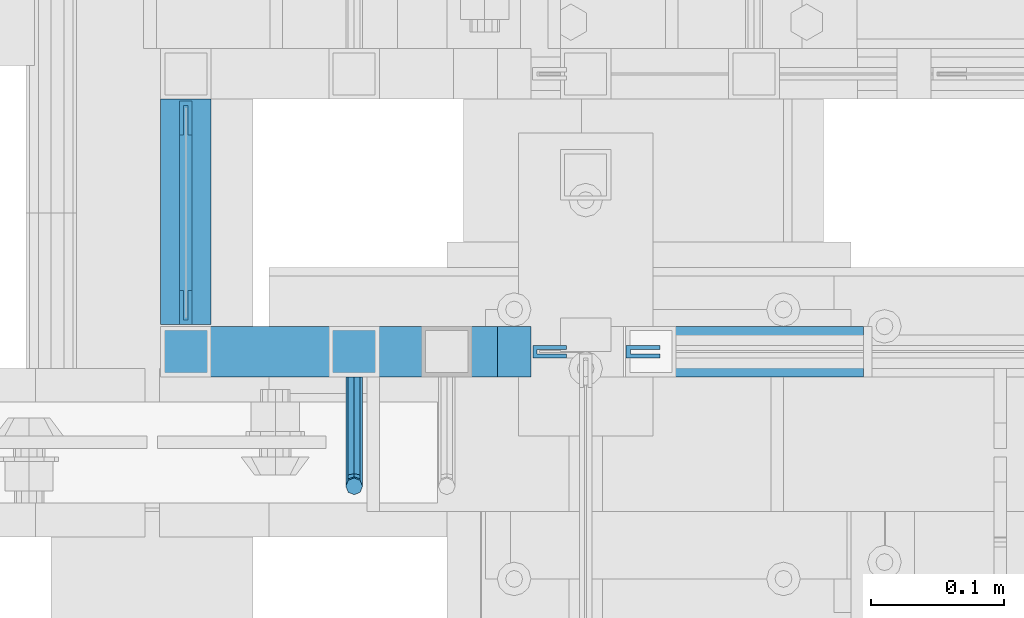
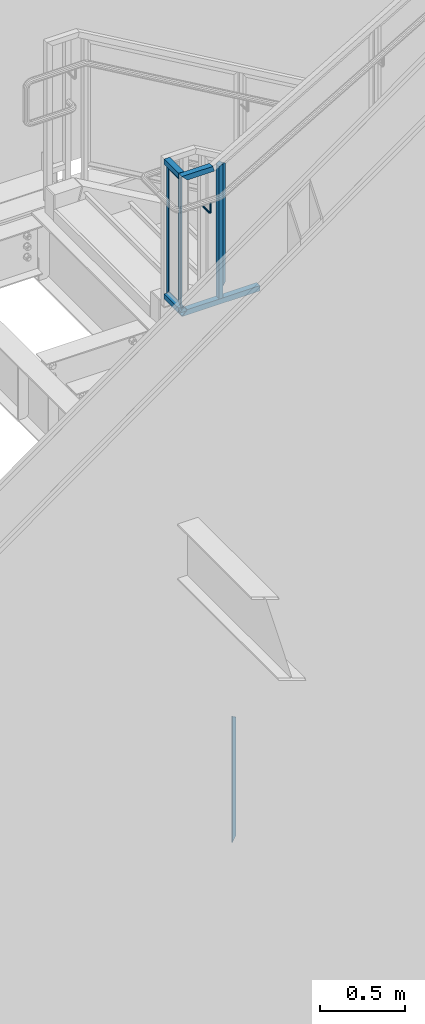
# One storey, part 908 of 1179: 9 beams, 2 members, 3 elements without a shape of their own.
"""IFC2X3 building model written with IfcOpenShell, lengths in millimetres."""

from ifc_helpers import new_model, si_unit, frame, origin_with_axes, place, context, subcontext, project, spatial, faceted_brep, material, type_object, element, aggregate, save


model = new_model("IFC2X3")

# Units and contexts
model_context = context("Model", 3, precision=1e-05, world=origin_with_axes())
body_context = subcontext(model_context, "Body", "Model", "MODEL_VIEW")
ifc_project = project(units=[si_unit("LENGTHUNIT", "METRE", prefix="MILLI"), si_unit("AREAUNIT", "SQUARE_METRE"), si_unit("VOLUMEUNIT", "CUBIC_METRE"), si_unit("MASSUNIT", "GRAM", prefix="KILO"), si_unit("TIMEUNIT", "SECOND"), si_unit("PLANEANGLEUNIT", "RADIAN"), si_unit("SOLIDANGLEUNIT", "STERADIAN"), si_unit("THERMODYNAMICTEMPERATUREUNIT", "DEGREE_CELSIUS"), si_unit("LUMINOUSINTENSITYUNIT", "LUMEN")], contexts=[model_context])

# Site, building, storey
site_placement = place(None, origin_with_axes())
site = spatial("IfcSite", under=ifc_project, at=site_placement, CompositionType="ELEMENT")
building_placement = place(site_placement, origin_with_axes())
building = spatial("IfcBuilding", under=site, at=building_placement, Name="Undefined", CompositionType="ELEMENT")
storey_placement = place(building_placement, origin_with_axes())
storey = spatial("IfcBuildingStorey", under=building, at=storey_placement, Name="Undefined", CompositionType="ELEMENT", Elevation=0.0)

# Assembly, member
assembly_1_placement = place(storey_placement, origin_with_axes())
assembly_1 = element("IfcElementAssembly", 1, at=assembly_1_placement, inside=storey, Name="GUARDRAIL", AssemblyPlace="NOTDEFINED", PredefinedType="RIGID_FRAME")
ifc_material_1 = material(Name="STEEL/A36")
member_type_1 = type_object("IfcMemberType", PredefinedType="NOTDEFINED")
member_1_placement = place(assembly_1_placement, frame((19551.6499976895, 39471.5999992249, 4349.74999847), z_axis=(0.0, -1.0, 0.0), x_axis=(0.0, 0.0, 1.0)))
member_1 = element("IfcMember", 2, at=member_1_placement, type_object=member_type_1, material=ifc_material_1, Name="POST", context=body_context, shape_type="Brep", body=[
    faceted_brep([(967.487411799532, -12.7000000000007, 19.0500000000029), (967.487411799532, -12.7000000000007, -19.0500000000029), (952.670745120644, 12.7000000000007, -19.0500000000029), (952.670745120644, 12.7000000000007, 19.0500000000029), (0.0, -12.7000000000007, -19.0500000000029), (0.0, -12.7000000000007, 19.0500000000029), (0.0, 12.7000000000007, 19.0500000000029), (0.0, 12.7000000000007, -19.0500000000029)], [[[0, 1, 2, 3]], [[4, 5, 6, 7]], [[6, 5, 0, 3]], [[7, 6, 3, 2]], [[4, 7, 2, 1]], [[5, 4, 1, 0]]]),
])

# Assembly, beams
assembly_2_placement = place(storey_placement, origin_with_axes())
assembly_2 = element("IfcElementAssembly", 3, at=assembly_2_placement, inside=storey, Name="GUARDRAIL", AssemblyPlace="NOTDEFINED", PredefinedType="RIGID_FRAME")
ifc_material_2 = material(Name="STEEL/BUY-OUT")
beam_type_1 = type_object("IfcBeamType", PredefinedType="NOTDEFINED")
beam_1_placement = place(assembly_2_placement, frame((19307.1749999845, 39635.1125013617, 4816.47500076595), z_axis=(0.0, 0.0, -1.0), x_axis=(0.0, 1.0, 0.0)))
beam_1 = element("IfcBeam", 4, at=beam_1_placement, type_object=beam_type_1, material=ifc_material_2, Name="U-EDGE", context=body_context, shape_type="Brep", body=[
    faceted_brep([(0.0, 1.58750000000146, 439.737503057808), (0.0, -1.58750000000146, 439.737503057808), (22.2250001847788, -1.58750000000146, 461.962502362523), (22.2250001847788, -4.76249999999709, 461.962502362523), (3.69283952750266e-07, -4.76249999999709, 439.737503427092), (3.69283952750266e-07, -7.9375, 439.737503427092), (25.4000001847817, -7.9375, 465.1375), (25.4000001847817, 1.58750000000146, 465.1375), (25.4000001847817, -7.9375, -465.1375), (25.4000001847817, 1.58750000000146, -465.1375), (0.0, 1.58750000000146, -439.737499661022), (0.0, -1.58750000000146, -439.737499661022), (22.2250001847788, -1.58750000000146, -461.962499971525), (22.2250001847788, -4.76249999999709, -461.962499971525), (3.69283952750266e-07, -4.76249999999709, -439.737500030305), (3.69283952750266e-07, -7.9375, -439.737500030305)], [[[0, 1, 2, 3, 4, 5, 6, 7]], [[7, 6, 8, 9]], [[0, 7, 9, 10]], [[1, 0, 10, 11]], [[2, 1, 11, 12]], [[3, 2, 12, 13]], [[4, 3, 13, 14]], [[5, 4, 14, 15]], [[6, 5, 15, 8]], [[14, 13, 12, 11, 10, 9, 8, 15]]]),
])
beam_2_placement = place(assembly_2_placement, frame((19307.1749999845, 39563.6750014964, 5256.21250076183), z_axis=(0.0, -1.0, 0.0), x_axis=(0.0, 0.0, 1.0)))
beam_2 = element("IfcBeam", 5, at=beam_2_placement, type_object=beam_type_1, material=ifc_material_2, Name="U-EDGE", context=body_context, shape_type="Brep", body=[
    faceted_brep([(7.59955582907423e-08, 7.9375, 46.0375032529701), (7.59955582907423e-08, 4.76249999999709, 46.0375032529701), (22.2250000381364, 4.76249999999709, 68.2625030893832), (22.2250000381364, 1.58750000000146, 68.2625030893832), (0.0, 1.58750000000146, 46.037500944738), (0.0, -1.58750000000146, 46.037500944738), (25.4000000381357, -1.58750000000146, 71.4375030714291), (25.4000000381357, 7.9375, 71.4375030714291), (25.4000000381357, -1.58750000000146, -96.8375000000015), (25.4000000381357, 7.9375, -96.8375000000015), (7.59955582907423e-08, 7.9375, -71.4374998836502), (7.59955582907423e-08, 4.76249999999709, -71.4374998836502), (22.2250000381364, 4.76249999999709, -93.6624999715132), (22.2250000381364, 1.58750000000146, -93.6624999715132), (0.0, 1.58750000000146, -71.4374998076601), (0.0, -1.58750000000146, -71.4374998076601)], [[[0, 1, 2, 3, 4, 5, 6, 7]], [[7, 6, 8, 9]], [[0, 7, 9, 10]], [[1, 0, 10, 11]], [[2, 1, 11, 12]], [[3, 2, 12, 13]], [[4, 3, 13, 14]], [[5, 4, 14, 15]], [[6, 5, 15, 8]], [[14, 13, 12, 11, 10, 9, 8, 15]]]),
])
beam_3_placement = place(assembly_2_placement, frame((19307.1749999845, 39517.6374986447, 4816.47500076595), z_axis=(0.0, 0.0, -1.0), x_axis=(0.0, -1.0, 0.0)))
beam_3 = element("IfcBeam", 6, at=beam_3_placement, type_object=beam_type_1, material=ifc_material_2, Name="U-EDGE", context=body_context, shape_type="Brep", body=[
    faceted_brep([(3.69283952750266e-07, 7.9375, 439.737503427122), (3.69283952750266e-07, 4.76249999999709, 439.737503427122), (22.2250001847788, 4.76249999999709, 461.962502362553), (22.2250001847788, 1.58750000000146, 461.962502362553), (0.0, 1.58750000000146, 439.737503057808), (0.0, -1.58750000000146, 439.737503057808), (25.4000001847817, -1.58750000000146, 465.1375), (25.4000001847817, 7.9375, 465.1375), (25.4000001847817, -1.58750000000146, -465.1375), (25.4000001847817, 7.9375, -465.1375), (3.69283952750266e-07, 7.9375, -439.7375000303), (3.69283952750266e-07, 4.76249999999709, -439.7375000303), (22.2250001847788, 4.76249999999709, -461.96249997152), (22.2250001847788, 1.58750000000146, -461.96249997152), (0.0, 1.58750000000146, -439.737499661022), (0.0, -1.58750000000146, -439.737499661022)], [[[0, 1, 2, 3, 4, 5, 6, 7]], [[7, 6, 8, 9]], [[0, 7, 9, 10]], [[1, 0, 10, 11]], [[2, 1, 11, 12]], [[3, 2, 12, 13]], [[4, 3, 13, 14]], [[5, 4, 14, 15]], [[6, 5, 15, 8]], [[14, 13, 12, 11, 10, 9, 8, 15]]]),
])

# Beam
beam_4_placement = place(assembly_1_placement, frame((19591.2581503392, 39468.4251646336, 4862.25422466768), z_axis=(0.0, 0.0, -1.0), x_axis=(-1.0, 0.0, 0.0)))
beam_4 = element("IfcBeam", 7, at=beam_4_placement, type_object=beam_type_1, material=ifc_material_2, Name="U-EDGE", context=body_context, shape_type="Brep", body=[
    faceted_brep([(0.0, 1.58750000000146, -439.43612632327), (0.0, -1.58750000000146, -439.43612632327), (0.0, -1.58750000000146, 409.802710675423), (0.0, 1.58750000000146, 409.802710675423), (22.2250000000313, 1.58750000000146, -452.201447879431), (22.2250000000313, 1.58750000000146, 448.497212762225), (22.2250000000313, 4.76249999999709, -452.201447879431), (22.2250000000313, 4.76249999999709, 448.497212762225), (6.54836185276508e-11, 4.76249999999709, -439.436126323308), (6.54836185276508e-11, 4.76249999999709, 409.802710675536), (6.54836185276508e-11, 7.9375, -439.436126323308), (6.54836185276508e-11, 7.9375, 409.802710675536), (25.4000000000342, 7.9375, -454.025), (25.4000000000342, 7.9375, 454.025), (25.4000000000342, -1.58750000000146, -454.025), (25.4000000000342, -1.58750000000146, 454.025)], [[[0, 1, 2, 3]], [[4, 0, 3, 5]], [[6, 4, 5, 7]], [[8, 6, 7, 9]], [[10, 8, 9, 11]], [[12, 10, 11, 13]], [[14, 12, 13, 15]], [[11, 9, 7, 5, 3, 2, 15, 13]], [[1, 14, 15, 2]], [[0, 4, 6, 8, 10, 12, 14, 1]]]),
])

# Assembly, beam
assembly_3_placement = place(storey_placement, origin_with_axes())
assembly_3 = element("IfcElementAssembly", 8, at=assembly_3_placement, inside=storey, Name="GUARDRAIL", AssemblyPlace="NOTDEFINED", PredefinedType="RIGID_FRAME")
beam_5_placement = place(assembly_3_placement, frame((19661.5843755731, 39468.4251653905, 843.573516189573), z_axis=(0.0, 0.0, -1.0), x_axis=(-1.0, 0.0, 0.0)))
beam_5 = element("IfcBeam", 9, at=beam_5_placement, type_object=beam_type_1, material=ifc_material_2, Name="U-EDGE", context=body_context, shape_type="Brep", body=[
    faceted_brep([(0.0, 1.58750000000146, -439.570271458992), (0.0, -1.58750000000146, -439.570271458992), (0.0, -1.58750000000146, 410.762302941614), (0.0, 1.58750000000146, 410.762302941614), (22.2250000000131, 1.58750000000146, -452.383647202629), (22.2250000000131, 1.58750000000146, 449.311912848919), (22.2250000000131, 4.76249999999709, -452.383647202629), (22.2250000000131, 4.76249999999709, 449.311912848919), (2.91038304567337e-11, 4.76249999999709, -439.570271459009), (2.91038304567337e-11, 4.76249999999709, 410.762303199042), (2.91038304567337e-11, 7.9375, -439.570271459009), (2.91038304567337e-11, 7.9375, 410.762303199042), (25.400000000016, 7.9375, -454.214129451719), (25.3999999999687, 7.9375, 454.819), (25.400000000016, -1.58750000000146, -454.214129451719), (25.3999999999687, -1.58750000000146, 454.819)], [[[0, 1, 2, 3]], [[4, 0, 3, 5]], [[6, 4, 5, 7]], [[8, 6, 7, 9]], [[10, 8, 9, 11]], [[12, 10, 11, 13]], [[14, 12, 13, 15]], [[11, 9, 7, 5, 3, 2, 15, 13]], [[1, 14, 15, 2]], [[0, 4, 6, 8, 10, 12, 14, 1]]]),
])
aggregate(assembly_3, [beam_5])

# Member
ifc_material_3 = material()
member_type_2 = type_object("IfcMemberType", Name="HSS1-1/2X1-1/2X1/8", PredefinedType="NOTDEFINED")
member_2_placement = place(assembly_1_placement, frame((19303.9999992195, 39471.6000005027, 4330.699999235), z_axis=(0.0, -1.0, 0.0), x_axis=(1.0, 0.0, 0.0)))
member_2 = element("IfcMember", 10, at=member_2_placement, type_object=member_type_2, material=ifc_material_3, Name="POST", ObjectType="HSS1-1/2X1-1/2X1/8", context=body_context, shape_type="Brep", body=[
    faceted_brep([(15.874999282998, 15.874999282998, -15.8749992829999), (-15.8749985180002, -15.8749992829999, -15.874999282998), (511.17500059307, -15.8749992829999, -15.874999282998), (511.17500059307, 15.8749992829999, -15.874999282998), (-15.8749992830017, -15.874999282998, 15.8749992829999), (511.17500059307, -15.8749992829999, 15.874999282998), (15.8750000479995, 15.8749992829999, 15.874999282998), (511.17500059307, 15.8749992829999, 15.874999282998), (19.0499999999993, 19.0499992349996, -19.0499992350015), (19.0499999999993, 19.0499992349996, 19.0499992350015), (511.17500059307, 19.0499992349996, 19.0499992350015), (511.17500059307, 19.0499992349996, -19.0499992350015), (-19.0499992350015, -19.0499992350015, 19.0499992349996), (511.17500059307, -19.0499992349996, 19.0499992350015), (-19.04999847, -19.0499992349996, -19.0499992350015), (511.17500059307, -19.0499992349996, -19.0499992350015)], [[[0, 1, 2, 3]], [[1, 4, 5, 2]], [[4, 6, 7, 5]], [[6, 0, 3, 7]], [[8, 9, 10, 11]], [[9, 12, 13, 10]], [[12, 14, 15, 13]], [[14, 8, 11, 15]], [[13, 15, 11, 10], [5, 7, 3, 2]], [[14, 12, 9, 8], [6, 4, 1, 0]]]),
])

# Beam
beam_type_2 = type_object("IfcBeamType", PredefinedType="NOTDEFINED")
beam_6_placement = place(assembly_1_placement, frame((19430.9999992195, 39452.5499992245, 5054.6), z_axis=(0.0, 0.0, 1.0), x_axis=(0.0, -1.0, 0.0)))
beam_6 = element("IfcBeam", 11, at=beam_6_placement, type_object=beam_type_2, material=ifc_material_1, Name="BRACKET", context=body_context, shape_type="Brep", body=[
    faceted_brep([(0.0, -6.34999999999854, 0.0), (0.0, -4.49012806053361, -4.49012806053452), (69.849999425729, -4.49012806053361, -4.49012806053452), (69.849999425729, -6.34999999999854, 0.0), (0.0, 0.0, -6.34999999999991), (69.849999425729, 0.0, -6.34999999999991), (0.0, 4.49012806053361, -4.49012806053452), (69.849999425729, 4.49012806053361, -4.49012806053452), (0.0, 6.34999999999854, 0.0), (69.849999425729, 6.34999999999854, 0.0), (0.0, 4.49012806053361, 4.49012806053452), (69.849999425729, 4.49012806053361, 4.49012806053452), (0.0, 0.0, 6.34999999999991), (69.849999425729, 0.0, 6.34999999999991), (0.0, -4.49012806053361, 4.49012806053452), (69.849999425729, -4.49012806053361, 4.49012806053452), (79.3749993303718, 0.0, -3.79778396764323), (78.445063360632, -4.49012806053361, -2.18708762028064), (76.1999993303689, -6.34999999999854, 1.70147734638658), (73.9549353000984, -4.49012806053361, 5.59004231305425), (73.024999330366, 0.0, 7.20073866041639), (73.9549353000984, 4.49012806053361, 5.59004231305425), (76.1999993303689, 6.34999999999854, 1.70147734638658), (78.445063360632, 4.49012806053361, -2.18708762028064), (84.7370868552753, 4.49012806053361, 4.10493587436031), (86.3477832026401, 0.0, 3.17499990462693), (80.8485218886053, 6.34999999999854, 6.34999990462893), (76.9599569219426, 4.49012806053361, 8.59506393489755), (75.3492605745778, 0.0, 9.52499990463093), (76.9599569219426, -4.49012806053361, 8.59506393489755), (80.8485218886053, -6.34999999999854, 6.34999990462893), (84.7370868552753, -4.49012806053361, 4.10493587436031), (87.0401272955278, 4.49012806053361, 12.6999998092651), (88.8999992349927, 0.0, 12.6999998092651), (82.5499992349942, 6.34999999999854, 12.6999998092651), (78.0598711744606, 4.49012806053361, 12.6999998092651), (76.1999992349956, 0.0, 12.6999998092651), (78.0598711744606, -4.49012806053361, 12.6999998092651), (82.5499992349942, -6.34999999999854, 12.6999998092651), (87.0401272955278, -4.49012806053361, 12.6999998092651), (87.0401272955278, -4.49012806053361, 76.2000000000007), (82.5499992349942, -6.34999999999854, 76.2000000000007), (88.8999992349927, 0.0, 76.2000000000003), (87.0401272955278, 4.49012806053361, 76.2000000000007), (82.5499992349942, 6.34999999999854, 76.2000000000007), (78.0598711744606, 4.49012806053361, 76.2000000000007), (76.1999992349956, 0.0, 76.2000000000003), (78.0598711744606, -4.49012806053361, 76.2000000000007)], [[[0, 1, 2, 3]], [[1, 4, 5, 2]], [[4, 6, 7, 5]], [[6, 8, 9, 7]], [[8, 10, 11, 9]], [[10, 12, 13, 11]], [[12, 14, 15, 13]], [[14, 0, 3, 15]], [[14, 12, 10, 8, 6, 4, 1, 0]], [[2, 5, 16, 17]], [[3, 2, 17, 18]], [[15, 3, 18, 19]], [[13, 15, 19, 20]], [[11, 13, 20, 21]], [[9, 11, 21, 22]], [[7, 9, 22, 23]], [[5, 7, 23, 16]], [[23, 24, 25, 16]], [[22, 26, 24, 23]], [[21, 27, 26, 22]], [[20, 28, 27, 21]], [[19, 29, 28, 20]], [[18, 30, 29, 19]], [[17, 31, 30, 18]], [[16, 25, 31, 17]], [[24, 32, 33, 25]], [[26, 34, 32, 24]], [[27, 35, 34, 26]], [[28, 36, 35, 27]], [[29, 37, 36, 28]], [[30, 38, 37, 29]], [[31, 39, 38, 30]], [[25, 33, 39, 31]], [[38, 39, 40, 41]], [[39, 33, 42, 40]], [[33, 32, 43, 42]], [[32, 34, 44, 43]], [[34, 35, 45, 44]], [[35, 36, 46, 45]], [[36, 37, 47, 46]], [[37, 38, 41, 47]], [[42, 43, 44, 45, 46, 47, 41, 40]]]),
])

beam_type_3 = type_object("IfcBeamType", Name="HSS1-1/2X1-1/2X1/8", PredefinedType="NOTDEFINED")
beam_7_placement = place(assembly_2_placement, frame((19303.9999999845, 39681.1501661867, 4330.699999235), z_axis=(0.0, 0.0, 1.0), x_axis=(0.0, -1.0, 0.0)))
beam_7 = element("IfcBeam", 12, at=beam_7_placement, type_object=beam_type_3, material=ifc_material_3, Name="POST", ObjectType="HSS1-1/2X1-1/2X1/8", context=body_context, shape_type="Brep", body=[
    faceted_brep([(19.0501654052205, -19.0499999999993, 19.0499992349996), (19.0501654052205, 19.0499992350015, 19.0499992349996), (19.0501654052205, 19.0499992350015, -19.0499992349996), (19.0501654052205, -19.0499992350015, -19.0499992349996), (19.0501654052205, -15.8749992830017, 15.8749992829999), (19.0501654052205, -15.8749992830017, -15.8749992829999), (19.0501654052205, 15.8749992830017, -15.8749992829999), (19.0501654052205, 15.8749992830017, 15.8749992829999), (188.912666448952, 19.0499992350015, -19.0499992349996), (188.912666448952, -19.0499992350015, -19.0499992349996), (188.912666448952, -19.0499992350015, 19.0499992349996), (188.912666448952, 19.0499992350015, 19.0499992349996), (188.912666448952, -15.8749992830017, 15.8749992829999), (188.912666448952, 15.8749992830017, 15.8749992829999), (188.912666448952, 15.8749992830017, -15.8749992829999), (188.912666448952, -15.8749992830017, -15.8749992829999)], [[[0, 1, 2, 3], [4, 5, 6, 7]], [[8, 9, 3, 2]], [[9, 10, 0, 3]], [[10, 11, 1, 0]], [[11, 8, 2, 1]], [[10, 9, 8, 11], [12, 13, 14, 15]], [[13, 12, 4, 7]], [[14, 13, 7, 6]], [[15, 14, 6, 5]], [[12, 15, 5, 4]]]),
])

beam_8_placement = place(assembly_2_placement, frame((19303.9999999845, 39662.100001542, 5302.24999999716), z_axis=(0.0, 0.0, 1.0), x_axis=(0.0, -1.0, 0.0)))
beam_8 = element("IfcBeam", 13, at=beam_8_placement, type_object=beam_type_3, material=ifc_material_3, Name="POST", ObjectType="HSS1-1/2X1-1/2X1/8", context=body_context, shape_type="Brep", body=[
    faceted_brep([(0.0, 15.8749992830017, -15.8749992829999), (0.0, -15.8749992830017, -15.8749992829999), (169.862503082084, -15.8749992830017, -15.8749992829999), (169.862503082084, 15.8749992830017, -15.8749992829999), (0.0, -15.8749992830017, 15.8749992829999), (169.862503082084, -15.8749992830017, 15.8749992829999), (0.0, 15.8749992830017, 15.8749992829999), (169.862503082084, 15.8749992830017, 15.8749992829999), (0.0, 19.0499992350015, -19.0499992349996), (0.0, 19.0499992350015, 19.0499992349996), (169.862503082084, 19.0499992350015, 19.0499992349996), (169.862503082084, 19.0499992350015, -19.0499992349996), (0.0, -19.0499992350015, 19.0499992349996), (169.862503082084, -19.0499992350015, 19.0499992349996), (0.0, -19.0499992350015, -19.0499992349996), (169.862503082084, -19.0499992350015, -19.0499992349996)], [[[0, 1, 2, 3]], [[1, 4, 5, 2]], [[4, 6, 7, 5]], [[6, 0, 3, 7]], [[8, 9, 10, 11]], [[9, 12, 13, 10]], [[12, 14, 15, 13]], [[14, 8, 11, 15]], [[13, 15, 11, 10], [5, 7, 3, 2]], [[14, 12, 9, 8], [6, 4, 1, 0]]]),
])

aggregate(assembly_2, [beam_1, beam_2, beam_3, beam_7, beam_8])

beam_9_placement = place(assembly_1_placement, frame((19303.9999999845, 39471.5999992249, 5302.25), z_axis=(0.0, 0.0, 1.0), x_axis=(1.0, 0.0, 0.0)))
beam_9 = element("IfcBeam", 14, at=beam_9_placement, type_object=beam_type_3, material=ifc_material_3, Name="TOP_RAIL", ObjectType="HSS1-1/2X1-1/2X1/8", context=body_context, shape_type="Brep", body=[
    faceted_brep([(15.874999282998, 15.874999282998, -15.8749992829999), (15.874999282998, -15.874999282998, -15.8749992829999), (201.141792859766, -15.874999282998, -15.8749992829999), (201.141792859766, 15.874999282998, -15.8749992829999), (-15.8749992830017, -15.874999282998, 15.8749992829999), (192.558208012601, -15.874999282998, 15.8749992829999), (-15.8749992830017, 15.874999282998, 15.8749992829999), (192.558208012601, 15.874999282998, 15.8749992829999), (19.0499999999993, 19.0499992349996, -19.0499992350015), (-19.0499992350015, 19.0499992350015, 19.0499992349996), (191.699849502093, 19.0499992350015, 19.0499992349996), (202.000151370274, 19.0499992350015, -19.0499992349996), (-19.0499992350015, -19.0499992350015, 19.0499992349996), (191.699849502093, -19.0499992350015, 19.0499992349996), (19.0499999999993, -19.0499992349996, -19.0499992350015), (202.000151370274, -19.0499992350015, -19.0499992349996)], [[[0, 1, 2, 3]], [[1, 4, 5, 2]], [[4, 6, 7, 5]], [[6, 0, 3, 7]], [[8, 9, 10, 11]], [[9, 12, 13, 10]], [[12, 14, 15, 13]], [[14, 8, 11, 15]], [[13, 15, 11, 10], [5, 7, 3, 2]], [[14, 12, 9, 8], [6, 4, 1, 0]]]),
])

aggregate(assembly_1, [beam_6, member_2, beam_9, beam_4, member_1])

save(model, "model.ifc")
